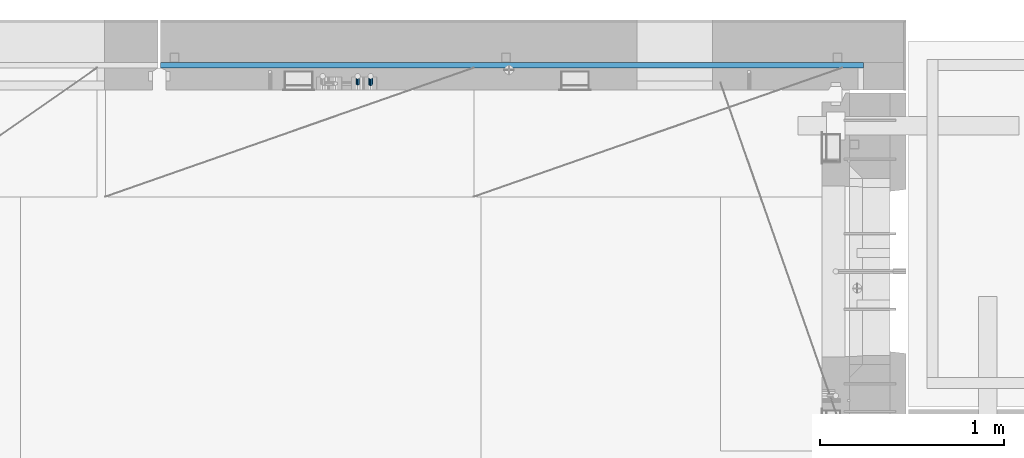
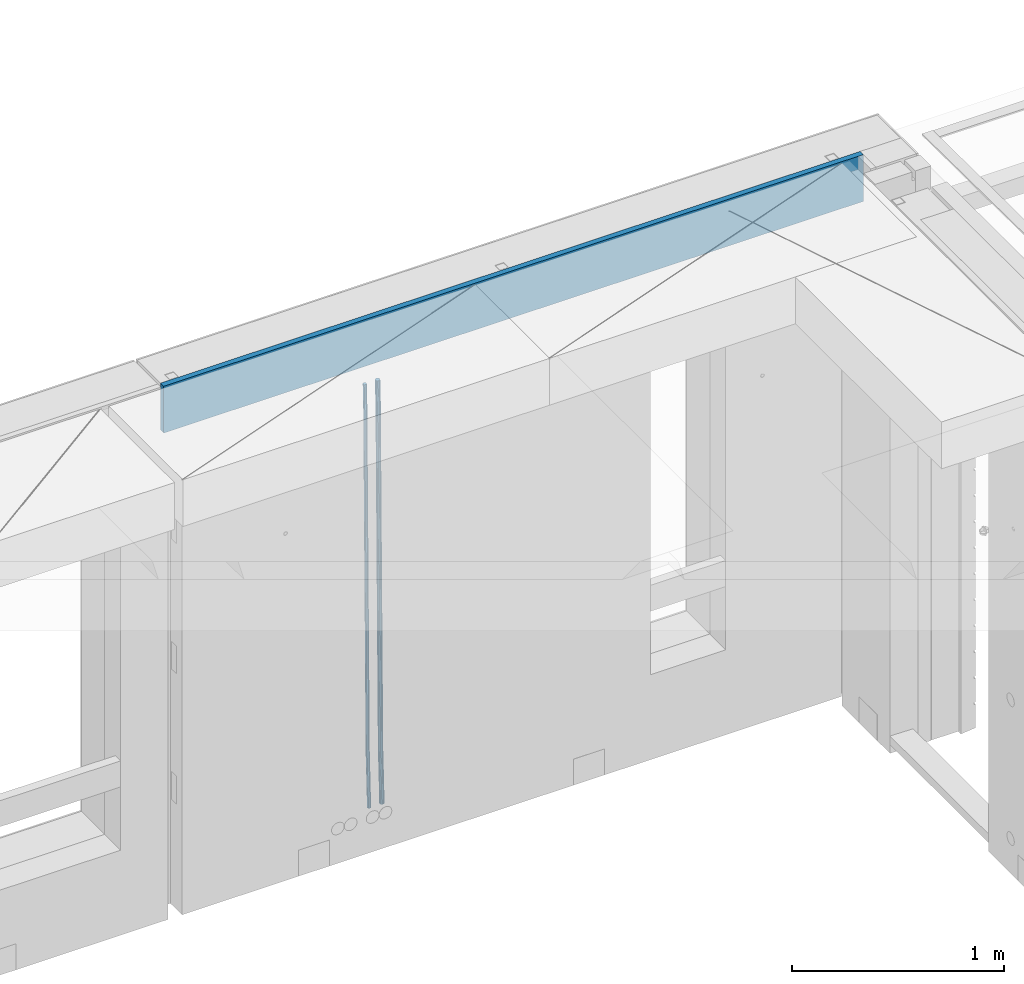
# One storey, part 128 of 349: 3 beams, 1 element without a shape of its own.
"""IFC2X3 building model written with IfcOpenShell, lengths in millimetres."""

from ifc_helpers import new_model, si_unit, frame, origin_with_axes, place, context, subcontext, project, spatial, faceted_brep, material, type_object, element, aggregate, save


model = new_model("IFC2X3")

# Units and contexts
model_context = context("Model", 3, precision=1e-05, world=origin_with_axes())
body_context = subcontext(model_context, "Body", "Model", "MODEL_VIEW")
ifc_project = project(units=[si_unit("LENGTHUNIT", "METRE", prefix="MILLI"), si_unit("AREAUNIT", "SQUARE_METRE"), si_unit("VOLUMEUNIT", "CUBIC_METRE"), si_unit("MASSUNIT", "GRAM", prefix="KILO"), si_unit("TIMEUNIT", "SECOND"), si_unit("PLANEANGLEUNIT", "RADIAN"), si_unit("SOLIDANGLEUNIT", "STERADIAN"), si_unit("THERMODYNAMICTEMPERATUREUNIT", "DEGREE_CELSIUS"), si_unit("LUMINOUSINTENSITYUNIT", "LUMEN")], contexts=[model_context])

# Site, building, storey
site_placement = place(None, origin_with_axes())
site = spatial("IfcSite", under=ifc_project, at=site_placement, CompositionType="ELEMENT")
building_placement = place(site_placement, origin_with_axes())
building = spatial("IfcBuilding", under=site, at=building_placement, CompositionType="ELEMENT")
storey_placement = place(building_placement, origin_with_axes())
storey = spatial("IfcBuildingStorey", under=building, at=storey_placement, Name="4", CompositionType="ELEMENT", Elevation=0.0)

# Assembly, beams
assembly_placement = place(storey_placement, origin_with_axes())
assembly = element("IfcElementAssembly", 1, at=assembly_placement, inside=storey, AssemblyPlace="NOTDEFINED", PredefinedType="REINFORCEMENT_UNIT")
ifc_material_1 = material()
beam_type_1 = type_object("IfcBeamType", Name="D20", PredefinedType="NOTDEFINED")
beam_1_placement = place(assembly_placement, frame((28790.0000000039, 22654.9999977209, 90990.0), z_axis=(-0.000205762999925498, 0.999642804629538, -0.0267249099901004), x_axis=(4.30000201928125e-08, 0.0267249099948059, 0.999642825806181)))
beam_1 = element("IfcBeam", 2, at=beam_1_placement, type_object=beam_type_1, material=ifc_material_1, Name="JM20", ObjectType="D20", context=body_context, shape_type="Brep", body=[
    faceted_brep([(0.0, -10.0, 0.0), (-4.19531716033816e-08, -7.07106781186667, -7.07106781187031), (60.4266690400545, -7.0710677960451, -7.07106780570757), (60.4266690441291, -9.99999998418934, 6.15546014159918e-09), (0.0, 0.0, -10.0), (60.426669036824, 1.58106558956206e-08, -9.99999999384454), (4.196772351861e-08, 7.07106781186303, -7.07106781186667), (60.4266690363438, 7.07106782768096, -7.07106780570757), (0.0, 10.0, 0.0), (60.4266690388904, 10.0000000158179, 6.15182216279209e-09), (4.196772351861e-08, 7.07106781185939, 7.07106781185939), (60.4266690429649, 7.07106782768096, 7.07106781802577), (0.0, 0.0, 10.0), (60.4266690461809, 1.58179318532348e-08, 10.0000000061555), (-4.19531716033816e-08, -7.07106781187031, 7.07106781185939), (60.4266690466611, -7.07106779605238, 7.07106781802213), (61.0378400410118, -7.07106779588503, -7.07106780564936), (60.991799419251, -9.99999998403655, 6.21366780251265e-09), (61.0569027789461, 1.5985278878361e-08, -9.99999999378269), (61.0378209396877, 7.07106782784831, -7.07106780564936), (60.9917724058905, 10.0000000159635, 6.21366780251265e-09), (60.9457317841297, 7.07106782781193, 7.0710678180767), (60.9266690461809, 1.59488990902901e-08, 10.0000000062028), (60.9457508854539, -7.07106779591413, 7.0710678180767), (61.6489592143771, -7.07106614513759, -7.06310863441468), (61.5568818710308, -9.9999984576425, 0.00735959856683621), (61.6870830769039, 1.71821739058942e-06, -9.99179257185824), (61.6489210170112, 7.07106947854481, -7.06310888312146), (61.556827851804, 10.0000015422847, 0.00735924683976918), (61.4647505084577, 7.07106922979438, 7.07782747982128), (61.4266266459163, 1.36643211590126e-06, 10.0065114172685), (61.464788705809, -7.07106639389531, 7.07782772852806), (176.543135720174, -7.07075579406956, -5.56673531796696), (176.451058376813, -9.99968810657447, 1.50373291501455), (176.581259582701, 0.000312069292704109, -8.49541925541052), (176.543097522794, 7.07137982961285, -5.56673556667374), (176.451004357587, 10.00031189336, 1.50373256329476), (176.35892701424, 7.07137958085514, 8.57420079627263), (176.320803151699, 0.000311717507429421, 11.5028847337162), (176.358965211621, -7.07075604281999, 8.57420104497578), (177.098753836006, -7.07075429323595, -5.55949898843028), (176.98362511232, -9.99968666800123, 1.510669025065), (177.146421932586, 0.000313595905026887, -8.48805862247536), (177.098706077581, 7.07138133041735, -5.55949936166144), (176.983557571715, 10.0003133318824, 1.51066849724157), (176.868428848029, 7.07138095712435, 8.58083651073321), (176.820760751449, 0.000313067976094317, 11.5093961447819), (176.868476606425, -7.07075466652896, 8.58083688396073), (177.654312950661, -7.07075204110879, -5.54863964998367), (177.516135294456, -9.99968450931192, 1.52107783331303), (177.711524267797, 0.000315886711177882, -8.47701274570863), (177.654255632195, 7.07138358250813, -5.54864021007961), (177.516054233929, 10.0003154905207, 1.5210770412159), (177.377876577739, 7.0713830223176, 8.59079452451624), (177.320665260588, 0.000315094497636892, 11.5191676202448), (177.377933896176, -7.07075260129932, 8.59079508461218), (299.436796249574, -7.07025836271714, -3.1681962331204), (299.298618593355, -9.99919083092027, 3.90152125031091), (299.494007566798, 0.000809565110102994, -6.09656932889993), (299.436738931283, 7.07187726089978, -3.16819679320906), (299.298537533061, 10.0008091689197, 3.90152045822106), (299.160359876842, 7.07187670072017, 10.9712379416487), (299.103148559603, 0.000808772889286047, 13.8996110374392), (299.160417195119, -7.07025892290039, 10.9712385017483), (299.98743051647, -7.07025613056248, -3.15743315966392), (299.971788958996, -9.99918809853989, 3.91467979818117), (299.993912075952, 0.000811591617093654, -6.08679785393178), (299.987423933868, 7.07187949325817, -3.1574327280432), (299.971753863239, 10.0008119014747, 3.91467990454839), (299.95611230444, 7.07187992653053, 10.9867922621015), (299.949630744944, 0.000812204350950196, 13.9161569563694), (299.956118887014, -7.07025569729012, 10.9867918304735), (300.538107039494, -7.07025785017686, -3.16575821840888), (300.644985195438, -9.99919020432935, 3.90450175465594), (300.493854948218, 0.000810030429420294, -6.09435592770024), (300.538151196495, 7.071877773491, -3.16575855385963), (300.645047642858, 10.0008097955724, 3.90450128024895), (300.751925798773, 7.07187744142357, 10.9747612533101), (300.796177890064, 0.000809560813650023, 13.9033589625978), (300.751881641787, -7.07025818224065, 10.9747615887682), (2293.36490490142, -7.07648090940347, -33.2930642912361), (2293.47178305736, -10.0054132635523, -26.2228043181785), (2293.32065281013, -0.00541302880083094, -36.2216620005347), (2293.36494905842, 7.06565471425711, -33.2930646266868), (2293.47184550477, 9.99458673634581, -26.2228047925819), (2293.57872366071, 7.06565438219332, -19.1525448195243), (2293.62297575199, -0.00541349841296324, -16.2239471102366), (2293.57867950371, -7.0764812414709, -19.1525444840736), (2294.0658245362, -7.07648309818615, -33.3036607065333), (2294.05312277409, -10.0054150789219, -26.2315929392535), (2294.10928714235, -0.00541549149056664, -36.2335844756526), (2294.15805078732, 7.06565223761572, -33.3050546393533), (2294.18355038921, 9.99458451388637, -26.2335642579346), (2294.17084862708, 7.06565253314329, -19.1614964906439), (2294.12738602093, -0.00541507354500936, -16.2315727215355), (2294.07862237596, -7.07648280265857, -19.1601025578348), (2294.76670261032, -7.08562269121467, -33.294332712383), (2294.63442802057, -10.0129954178956, -26.2238563411993), (2294.89787471293, -0.0156988342423574, -36.2230891548279), (2294.95110548967, 7.05531064255774, -33.2944998654275), (2294.89521307347, 9.98530428734011, -26.2240927312887), (2294.76293848372, 7.0579315606592, -19.1536163601049), (2294.63176638114, -0.0119922963167483, -16.2248599176673), (2294.57853560438, -7.08300177311321, -19.1534492070678), (2316.52657204497, -7.36937582653991, -33.0047303660212), (2316.39429745522, -10.2967485532172, -25.9342539948302), (2316.65774414754, -0.299451969567599, -35.9334868084661), (2316.7109749243, 6.7715575072325, -33.0048975190657), (2316.65508250811, 9.70155115201487, -25.9344903849269), (2316.52280791836, 6.7741784253376, -18.8640140137468), (2316.39163581574, -0.295745431634714, -15.9352575713092), (2316.33840503903, -7.36675490843481, -18.863846860706), (2317.16202064224, -7.37766220584308, -32.9962731735213), (2317.05438744847, -10.3053562613532, -25.9254688497131), (2317.23607125619, -0.306993473008333, -35.925789846493), (2317.23316144495, 6.76474808850253, -32.9979477328052), (2317.15499573652, 9.6950321815566, -25.9278370341635), (2317.04736254275, 6.7673381260538, -18.8570327103698), (2316.97331192881, -0.303330606784584, -15.9275160373909), (2316.97622174003, -7.37507216829545, -18.8553581510787), (2317.79752306276, -7.37578610372293, -32.9880110666527), (2317.71453320107, -10.3033876998124, -25.9168792378296), (2317.81444760226, -0.305295583297266, -35.918287695793), (2317.75539265381, 6.76628640723357, -32.9911928173897), (2317.65495180529, 9.69652304524061, -25.9213789128698), (2317.5719619436, 6.76892144914746, -18.8502470840467), (2317.55503740412, -0.301569071270933, -15.9199704549137), (2317.61409235255, -7.3731510618054, -18.847065333317), (2417.8183084176, -7.07752398473531, -31.6906369377139), (2417.73531855589, -10.0051255808248, -24.6195051088798), (2417.83523295709, -0.007033464313281, -34.6209135668432), (2417.77617800863, 7.06454852621755, -31.6938186884508), (2417.67573716014, 9.99478516423187, -24.6240047839383), (2417.59274729842, 7.06718356813872, -17.5528729551006), (2417.57582275895, -0.00330695228694822, -14.6225963259749), (2417.6348777074, -7.07488894281778, -17.5496912043673)], [[[0, 1, 2, 3]], [[1, 4, 5, 2]], [[4, 6, 7, 5]], [[6, 8, 9, 7]], [[8, 10, 11, 9]], [[10, 12, 13, 11]], [[12, 14, 15, 13]], [[14, 0, 3, 15]], [[14, 12, 10, 8, 6, 4, 1, 0]], [[3, 2, 16, 17]], [[2, 5, 18, 16]], [[5, 7, 19, 18]], [[7, 9, 20, 19]], [[9, 11, 21, 20]], [[11, 13, 22, 21]], [[13, 15, 23, 22]], [[15, 3, 17, 23]], [[17, 16, 24, 25]], [[16, 18, 26, 24]], [[18, 19, 27, 26]], [[19, 20, 28, 27]], [[20, 21, 29, 28]], [[21, 22, 30, 29]], [[22, 23, 31, 30]], [[23, 17, 25, 31]], [[25, 24, 32, 33]], [[24, 26, 34, 32]], [[26, 27, 35, 34]], [[27, 28, 36, 35]], [[28, 29, 37, 36]], [[29, 30, 38, 37]], [[30, 31, 39, 38]], [[31, 25, 33, 39]], [[33, 32, 40, 41]], [[32, 34, 42, 40]], [[34, 35, 43, 42]], [[35, 36, 44, 43]], [[36, 37, 45, 44]], [[37, 38, 46, 45]], [[38, 39, 47, 46]], [[39, 33, 41, 47]], [[41, 40, 48, 49]], [[40, 42, 50, 48]], [[42, 43, 51, 50]], [[43, 44, 52, 51]], [[44, 45, 53, 52]], [[45, 46, 54, 53]], [[46, 47, 55, 54]], [[47, 41, 49, 55]], [[49, 48, 56, 57]], [[48, 50, 58, 56]], [[50, 51, 59, 58]], [[51, 52, 60, 59]], [[52, 53, 61, 60]], [[53, 54, 62, 61]], [[54, 55, 63, 62]], [[55, 49, 57, 63]], [[57, 56, 64, 65]], [[56, 58, 66, 64]], [[58, 59, 67, 66]], [[59, 60, 68, 67]], [[60, 61, 69, 68]], [[61, 62, 70, 69]], [[62, 63, 71, 70]], [[63, 57, 65, 71]], [[65, 64, 72, 73]], [[64, 66, 74, 72]], [[66, 67, 75, 74]], [[67, 68, 76, 75]], [[68, 69, 77, 76]], [[69, 70, 78, 77]], [[70, 71, 79, 78]], [[71, 65, 73, 79]], [[73, 72, 80, 81]], [[72, 74, 82, 80]], [[74, 75, 83, 82]], [[75, 76, 84, 83]], [[76, 77, 85, 84]], [[77, 78, 86, 85]], [[78, 79, 87, 86]], [[79, 73, 81, 87]], [[81, 80, 88, 89]], [[80, 82, 90, 88]], [[82, 83, 91, 90]], [[83, 84, 92, 91]], [[84, 85, 93, 92]], [[85, 86, 94, 93]], [[86, 87, 95, 94]], [[87, 81, 89, 95]], [[89, 88, 96, 97]], [[88, 90, 98, 96]], [[90, 91, 99, 98]], [[91, 92, 100, 99]], [[92, 93, 101, 100]], [[93, 94, 102, 101]], [[94, 95, 103, 102]], [[95, 89, 97, 103]], [[97, 96, 104, 105]], [[96, 98, 106, 104]], [[98, 99, 107, 106]], [[99, 100, 108, 107]], [[100, 101, 109, 108]], [[101, 102, 110, 109]], [[102, 103, 111, 110]], [[103, 97, 105, 111]], [[105, 104, 112, 113]], [[104, 106, 114, 112]], [[106, 107, 115, 114]], [[107, 108, 116, 115]], [[108, 109, 117, 116]], [[109, 110, 118, 117]], [[110, 111, 119, 118]], [[111, 105, 113, 119]], [[113, 112, 120, 121]], [[112, 114, 122, 120]], [[114, 115, 123, 122]], [[115, 116, 124, 123]], [[116, 117, 125, 124]], [[117, 118, 126, 125]], [[118, 119, 127, 126]], [[119, 113, 121, 127]], [[121, 120, 128, 129]], [[120, 122, 130, 128]], [[122, 123, 131, 130]], [[123, 124, 132, 131]], [[124, 125, 133, 132]], [[125, 126, 134, 133]], [[126, 127, 135, 134]], [[127, 121, 129, 135]], [[130, 131, 132, 133, 134, 135, 129, 128]]]),
])
beam_type_2 = type_object("IfcBeamType", Name="D25", PredefinedType="NOTDEFINED")
beam_2_placement = place(assembly_placement, frame((28860.0000000039, 22654.9999977209, 90990.0), z_axis=(-0.000205762999925498, 0.999642804629538, -0.0267249099901004), x_axis=(4.30000201928125e-08, 0.0267249099948059, 0.999642825806181)))
beam_2 = element("IfcBeam", 3, at=beam_2_placement, type_object=beam_type_2, material=ifc_material_1, Name="JM25", ObjectType="D25", context=body_context, shape_type="Brep", body=[
    faceted_brep([(-7.41420080885291e-08, -12.5, -3.63797880709171e-12), (-6.42030499875546e-08, -10.8253175473074, -6.25000000000364), (60.4103898235917, -10.8253175318459, -6.2499999938409), (60.4103898269532, -12.4999999845422, 6.16273609921336e-09), (-3.70782800018787e-08, -6.25000000000364, -10.8253175473074), (60.4103898202884, -6.24999998454587, -10.8253175411446), (-1.45519152283669e-11, -3.63797880709171e-12, -12.5), (60.4103898179019, 1.54577719513327e-08, -12.4999999938373), (3.70637280866504e-08, 6.25, -10.8253175473074), (60.410389817087, 6.25000001545777, -10.825317541141), (6.42030499875546e-08, 10.8253175473001, -6.25000000000364), (60.410389818062, 10.8253175627578, -6.24999999383726), (7.41420080885291e-08, 12.4999999999927, 0.0), (60.4103898205503, 12.5000000154541, 6.16273609921336e-09), (6.42176019027829e-08, 10.8253175473001, 6.24999999999636), (60.4103898238973, 10.8253175627651, 6.2500000061591), (3.70928319171071e-08, 6.24999999999636, 10.8253175473037), (60.4103898272151, 6.25000001546141, 10.8253175534664), (1.45519152283669e-11, -3.63797880709171e-12, 12.4999999999964), (60.4103898296162, 1.54541339725256e-08, 12.5000000061591), (-3.7049176171422e-08, -6.25000000000364, 10.8253175473001), (60.4103898304165, -6.24999998454587, 10.8253175534701), (-6.41884980723262e-08, -10.8253175473074, 6.25), (60.4103898294561, -10.8253175318459, 6.25000000616637), (61.0324985728803, -10.8253175316895, -6.24999999377542), (60.991802792938, -12.4999999843931, 6.22458173893392e-09), (61.0622854283865, -6.24999998437852, -10.8253175410755), (61.0731819955545, 1.5628756955266e-08, -12.4999999937718), (61.0622685480339, 6.25000001562512, -10.8253175410791), (61.032469335245, 10.8253175629216, -6.24999999377178), (60.9917690322181, 12.5000000156033, 6.22458173893392e-09), (60.9510732522613, 10.8253175629034, 6.25000000621731), (60.9212863967696, 6.25000001558874, 10.8253175535247), (60.9103898296162, 1.55814632307738e-08, 12.5000000062137), (60.9213032771368, -6.24999998441126, 10.8253175535174), (60.9511024898966, -10.8253175317113, 6.25000000621731), (61.6545545670233, -10.8253158516927, -6.24189838219536), (61.573166454793, -12.499998414296, 0.00757164385504439), (61.7141257553885, -6.24999822394238, -10.8168280205282), (61.7359179680789, 1.80548886419274e-06, -12.491368569139), (61.7140919992817, 6.25000177601396, -10.8168282403167), (61.6544960997562, 10.8253192428383, -6.2418987628771), (61.5730989426083, 12.5000015856094, 0.0075712042817031), (61.4917108303925, 10.8253190230062, 6.25704123032847), (61.4321396420273, 6.25000139525582, 10.8319708686649), (61.4103474293224, 1.36582457344048e-06, 12.5065114172721), (61.4321733981196, -6.24999860470052, 10.8319710884571), (61.4917692976451, -10.8253160715249, 6.25704161101385), (176.524302641745, -10.8250056210964, -4.74584321979273), (176.442914529529, -12.4996881836996, 1.50362680625403), (176.583873830095, -6.24968799334965, -9.3207728581292), (176.605666042786, 0.000312036081595579, -10.9953134067364), (176.583840074018, 6.25031200660669, -9.32077307791769), (176.524244174492, 10.8256294734347, -4.74584360047811), (176.44284701733, 12.5003118162058, 1.50362636668069), (176.361458905099, 10.8256292535989, 7.75309639272746), (176.301887716749, 6.25031162585219, 12.3280260310676), (176.280095504058, 0.000311596420942806, 14.0025665796711), (176.301921472827, -6.24968837410415, 12.3280262508561), (176.361517372367, -10.8250058409321, 7.75309677341284), (177.085397012124, -10.8250041057399, -4.73853556792164), (176.983633547483, -12.4996867233749, 1.51066909103247), (177.159881729676, -6.24968643771717, -9.31327097355097), (177.187129580227, 0.000313606451527448, -10.987740468332), (177.159839524218, 6.25031356221734, -9.31327130338468), (177.085323910098, 10.8256309887511, -4.73853613920801), (176.983549136537, 12.5003132764905, 1.51066843136869), (176.881785671867, 10.8256306588555, 7.7598730903228), (176.80730095433, 6.25031299082912, 12.3346084959521), (176.780053103794, 0.000312946667690994, 14.0090779907332), (176.807343159802, -6.2496870091054, 12.3346088257895), (176.881858773908, -10.8250044356355, 7.7598736616128), (177.646431799818, -10.8250018318176, -4.72756919822132), (177.524295146417, -12.4996845320202, 1.52123723245313), (177.735828462886, -6.24968410334986, -9.30201312475765), (177.768531371941, 0.00031596292683389, -10.9763759912421), (177.735777808921, 6.25031589654827, -9.30201361973741), (177.646344064575, 10.8256332626152, -4.72757005553649), (177.524193838486, 12.5003154677688, 1.52123624250817), (177.402057185071, 10.8256327675663, 7.77004267317898), (177.312660521988, 6.2503150390985, 12.3444865997226), (177.279957612933, 0.00031497282179771, 14.0188494661961), (177.312711175953, -6.24968496079964, 12.3444870946951), (177.402144920314, -10.8250023268702, 7.77004353049415), (299.377443161706, -10.8245084454466, -2.34813158632096), (299.255306508276, -12.4991911456491, 3.90067484435349), (299.466839824803, -6.24919071697514, -6.92257551286093), (299.499542733873, 0.0008093492979242, -8.59693837933446), (299.466789170867, 6.250809282923, -6.92257600783341), (299.377355426492, 10.8261266489935, -2.34813244364341), (299.255205200388, 12.5008088541435, 3.90067385440125), (299.133068546944, 10.826126153941, 10.1494802850757), (299.043671883861, 6.25080842546959, 14.7239242116229), (299.010968974762, 0.000808359200163977, 16.3982870780892), (299.043722537797, -6.24919157442127, 14.7239247065918), (299.133156282158, -10.8245089404954, 10.1494811423981), (299.98561436501, -10.8245059804758, -2.33624385599614), (299.97179243555, -12.4991882411778, 3.91467976726199), (299.995742293278, -6.24918857328521, -6.91223722345239), (299.999447243041, 0.000811375455668895, -8.58716690387519), (299.995736475976, 6.25081142679483, -6.91223684201032), (299.985604289133, 10.8261291142808, -2.33624319533556), (299.971750386685, 12.5008117588586, 3.91467993563856), (299.957928457196, 10.8261294971744, 10.1656035610831), (299.947800528913, 6.25081208998381, 14.7415969285394), (299.944095579151, 0.00081214124293183, 16.4165266089549), (299.947806346216, -6.24918791008895, 14.7415965471009), (299.957938533058, -10.8245055975785, 10.1656029004225), (300.593832239858, -10.8245078794353, -2.34543881707941), (300.688302931099, -12.4991904788549, 3.90384712594823), (300.524685350189, -6.24919022474205, -6.92023371784308), (300.499390115292, 0.000809814544481924, -8.59472497713432), (300.524724372954, 6.25080977519247, -6.92023401429469), (300.593899829313, 10.8261272150703, -2.34543933054374), (300.688380976673, 12.5008095210287, 3.90384653304136), (300.782851667915, 10.8261269216127, 10.1531324760799), (300.851998557599, 6.25080926691589, 14.7279273768363), (300.877293792495, 0.000809227632998955, 16.4024186361276), (300.851959534804, -6.24919073302226, 14.7279276732806), (300.782784078474, -10.8245081728965, 10.153132989537), (2293.32930409742, -10.8307295605009, -32.4713622331001), (2293.42377478865, -12.5054121599169, -26.2220762900724), (2293.26015720774, -6.2554119058077, -37.0461571338565), (2293.23486197284, -0.00541186651753378, -38.7206483931477), (2293.26019623051, 6.24458809413409, -37.0461574303008), (2293.32937168686, 10.8199055340046, -32.4713627465644), (2293.42385283421, 12.4945878399631, -26.2220768829684), (2293.51832352545, 10.8199052405434, -19.972790939948), (2293.58747041514, 6.24458758585388, -15.3979960391844), (2293.61276565003, -0.00541245343265473, -13.7235047798931), (2293.58743139236, -6.25541241408428, -15.3979957427327), (2293.51825593603, -10.8307298539585, -19.9727904264691), (2294.0420846676, -10.8307317859326, -32.4821379598216), (2294.03681932652, -12.5054140739521, -26.2313442200393), (2294.06778164886, -6.2554144273563, -37.0583666982457), (2294.10702478497, -0.00541458957013674, -38.7338336404937), (2294.14929890928, 6.24458531819619, -37.0595987724118), (2294.18327670435, 10.8199028679592, -32.4842719748667), (2294.1998538474, 12.4945854171456, -26.2338083683717), (2294.19458850632, 10.819903129126, -19.9830146285858), (2294.16889152506, 6.24458577054975, -15.4067858901581), (2294.12964838895, -0.0054140672327776, -13.7313189479173), (2294.08737426462, -6.2554139749991, -15.4055538159919), (2294.05339646956, -10.8307315247621, -19.9808806135297), (2294.75482297382, -10.84002603931, -32.4726521173216), (2294.64982751427, -12.513407826169, -26.2231856868602), (2294.87535820232, -6.26594539088183, -37.0476186524102), (2294.97913588268, -0.0167870967634371, -38.7222267036377), (2295.0383488692, 6.23299192477134, -37.0477663960555), (2295.03713108998, 10.8087684320271, -32.4729080168181), (2294.97580884799, 12.4844668051373, -26.2234811741473), (2294.87081338844, 10.8110850182784, -19.9740147436787), (2294.7502781599, 6.23700436985018, -15.3990482086047), (2294.64650047956, -0.0121539242718427, -13.7244401573698), (2294.58728749304, -6.26193294580662, -15.3989004649666), (2294.58850527227, -10.8377094530588, -19.9737588441894), (2316.44667268227, -11.1228921988077, -32.1839550346631), (2316.34167722271, -12.7962739856739, -25.9344886042054), (2316.56720791078, -6.54881155039038, -36.7589215697517), (2316.67098559113, -0.299653256264719, -38.4335296209792), (2316.73019857766, 5.95012576527006, -36.759069313397), (2316.72898079845, 10.5259022725259, -32.1842109341669), (2316.66765855643, 12.2016006456361, -25.9347840914961), (2316.56266309689, 10.5282188587698, -19.6853176610275), (2316.44212786836, 5.95413821035254, -15.1103511259389), (2316.33835018802, -0.295020083769487, -13.4357430747186), (2316.27913720149, -6.54479910530426, -15.1102033823008), (2316.28035498071, -11.1205756125637, -19.685061761531), (2317.13234804722, -11.1318335458927, -32.1748293731798), (2317.04181141085, -12.8054038787741, -25.9251705100723), (2317.2154741603, -6.5572650749491, -36.7502937866229), (2317.26891617525, -0.307450393454928, -38.4255717558117), (2317.27835434731, 5.94297770185585, -36.7517739018112), (2317.24125972588, 10.5192220504723, -32.1773930078925), (2317.16757178486, 12.1950816748285, -25.9281307404563), (2317.0770351485, 10.5215113419545, -19.6784718773561), (2316.99390903539, 5.94694287101083, -15.1030074639057), (2316.94046702047, -0.302871810494253, -13.4277294947169), (2316.9310288484, -6.55329990579412, -15.1015273487101), (2316.96812346982, -11.1295442544142, -19.6759082426288), (2317.81808136747, -11.1298054502913, -32.1659056455355), (2317.74200467508, -12.803315894289, -25.9160547315114), (2317.86379538118, -6.55536082026447, -36.7418676070083), (2317.8668976831, -0.305700748642266, -38.417815303761), (2317.82655701396, 5.94458339541234, -36.7446799039099), (2317.75358262347, 10.5207330230332, -32.1707766866384), (2317.66752794063, 12.1965725370646, -25.9216793252963), (2317.59145124823, 10.5230620930706, -19.6718284112721), (2317.54573723453, 5.94861746304377, -15.0958664497994), (2317.54263493262, -0.301042608574789, -13.4199187530394), (2317.58297560175, -6.55132675263303, -15.0930541529051), (2317.65594999224, -11.1274763802539, -19.6669573701693), (2417.81884292323, -10.831603083323, -30.8687911350135), (2417.74276623082, -12.505113527317, -24.618940220982), (2417.86455693691, -6.25715845329614, -35.4447530964935), (2417.86765923884, -0.00749838167394046, -37.1207007932499), (2417.82731856969, 6.24278576237703, -35.4475653933878), (2417.75434417921, 10.8189353900088, -30.8736621761236), (2417.66828949639, 12.494774904033, -24.6245648147851), (2417.59221280397, 10.8212644600353, -18.3747139007501), (2417.54649879028, 6.2468198300121, -13.79875193927), (2417.54339648837, -0.00284024161010166, -12.1228042425173), (2417.5837371575, -6.25312438566107, -13.795939642383), (2417.65671154798, -10.8292740132893, -18.3698428596399)], [[[0, 1, 2, 3]], [[1, 4, 5, 2]], [[4, 6, 7, 5]], [[6, 8, 9, 7]], [[8, 10, 11, 9]], [[10, 12, 13, 11]], [[12, 14, 15, 13]], [[14, 16, 17, 15]], [[16, 18, 19, 17]], [[18, 20, 21, 19]], [[20, 22, 23, 21]], [[22, 0, 3, 23]], [[22, 20, 18, 16, 14, 12, 10, 8, 6, 4, 1, 0]], [[3, 2, 24, 25]], [[2, 5, 26, 24]], [[5, 7, 27, 26]], [[7, 9, 28, 27]], [[9, 11, 29, 28]], [[11, 13, 30, 29]], [[13, 15, 31, 30]], [[15, 17, 32, 31]], [[17, 19, 33, 32]], [[19, 21, 34, 33]], [[21, 23, 35, 34]], [[23, 3, 25, 35]], [[25, 24, 36, 37]], [[24, 26, 38, 36]], [[26, 27, 39, 38]], [[27, 28, 40, 39]], [[28, 29, 41, 40]], [[29, 30, 42, 41]], [[30, 31, 43, 42]], [[31, 32, 44, 43]], [[32, 33, 45, 44]], [[33, 34, 46, 45]], [[34, 35, 47, 46]], [[35, 25, 37, 47]], [[37, 36, 48, 49]], [[36, 38, 50, 48]], [[38, 39, 51, 50]], [[39, 40, 52, 51]], [[40, 41, 53, 52]], [[41, 42, 54, 53]], [[42, 43, 55, 54]], [[43, 44, 56, 55]], [[44, 45, 57, 56]], [[45, 46, 58, 57]], [[46, 47, 59, 58]], [[47, 37, 49, 59]], [[49, 48, 60, 61]], [[48, 50, 62, 60]], [[50, 51, 63, 62]], [[51, 52, 64, 63]], [[52, 53, 65, 64]], [[53, 54, 66, 65]], [[54, 55, 67, 66]], [[55, 56, 68, 67]], [[56, 57, 69, 68]], [[57, 58, 70, 69]], [[58, 59, 71, 70]], [[59, 49, 61, 71]], [[61, 60, 72, 73]], [[60, 62, 74, 72]], [[62, 63, 75, 74]], [[63, 64, 76, 75]], [[64, 65, 77, 76]], [[65, 66, 78, 77]], [[66, 67, 79, 78]], [[67, 68, 80, 79]], [[68, 69, 81, 80]], [[69, 70, 82, 81]], [[70, 71, 83, 82]], [[71, 61, 73, 83]], [[73, 72, 84, 85]], [[72, 74, 86, 84]], [[74, 75, 87, 86]], [[75, 76, 88, 87]], [[76, 77, 89, 88]], [[77, 78, 90, 89]], [[78, 79, 91, 90]], [[79, 80, 92, 91]], [[80, 81, 93, 92]], [[81, 82, 94, 93]], [[82, 83, 95, 94]], [[83, 73, 85, 95]], [[85, 84, 96, 97]], [[84, 86, 98, 96]], [[86, 87, 99, 98]], [[87, 88, 100, 99]], [[88, 89, 101, 100]], [[89, 90, 102, 101]], [[90, 91, 103, 102]], [[91, 92, 104, 103]], [[92, 93, 105, 104]], [[93, 94, 106, 105]], [[94, 95, 107, 106]], [[95, 85, 97, 107]], [[97, 96, 108, 109]], [[96, 98, 110, 108]], [[98, 99, 111, 110]], [[99, 100, 112, 111]], [[100, 101, 113, 112]], [[101, 102, 114, 113]], [[102, 103, 115, 114]], [[103, 104, 116, 115]], [[104, 105, 117, 116]], [[105, 106, 118, 117]], [[106, 107, 119, 118]], [[107, 97, 109, 119]], [[109, 108, 120, 121]], [[108, 110, 122, 120]], [[110, 111, 123, 122]], [[111, 112, 124, 123]], [[112, 113, 125, 124]], [[113, 114, 126, 125]], [[114, 115, 127, 126]], [[115, 116, 128, 127]], [[116, 117, 129, 128]], [[117, 118, 130, 129]], [[118, 119, 131, 130]], [[119, 109, 121, 131]], [[121, 120, 132, 133]], [[120, 122, 134, 132]], [[122, 123, 135, 134]], [[123, 124, 136, 135]], [[124, 125, 137, 136]], [[125, 126, 138, 137]], [[126, 127, 139, 138]], [[127, 128, 140, 139]], [[128, 129, 141, 140]], [[129, 130, 142, 141]], [[130, 131, 143, 142]], [[131, 121, 133, 143]], [[133, 132, 144, 145]], [[132, 134, 146, 144]], [[134, 135, 147, 146]], [[135, 136, 148, 147]], [[136, 137, 149, 148]], [[137, 138, 150, 149]], [[138, 139, 151, 150]], [[139, 140, 152, 151]], [[140, 141, 153, 152]], [[141, 142, 154, 153]], [[142, 143, 155, 154]], [[143, 133, 145, 155]], [[145, 144, 156, 157]], [[144, 146, 158, 156]], [[146, 147, 159, 158]], [[147, 148, 160, 159]], [[148, 149, 161, 160]], [[149, 150, 162, 161]], [[150, 151, 163, 162]], [[151, 152, 164, 163]], [[152, 153, 165, 164]], [[153, 154, 166, 165]], [[154, 155, 167, 166]], [[155, 145, 157, 167]], [[157, 156, 168, 169]], [[156, 158, 170, 168]], [[158, 159, 171, 170]], [[159, 160, 172, 171]], [[160, 161, 173, 172]], [[161, 162, 174, 173]], [[162, 163, 175, 174]], [[163, 164, 176, 175]], [[164, 165, 177, 176]], [[165, 166, 178, 177]], [[166, 167, 179, 178]], [[167, 157, 169, 179]], [[169, 168, 180, 181]], [[168, 170, 182, 180]], [[170, 171, 183, 182]], [[171, 172, 184, 183]], [[172, 173, 185, 184]], [[173, 174, 186, 185]], [[174, 175, 187, 186]], [[175, 176, 188, 187]], [[176, 177, 189, 188]], [[177, 178, 190, 189]], [[178, 179, 191, 190]], [[179, 169, 181, 191]], [[181, 180, 192, 193]], [[180, 182, 194, 192]], [[182, 183, 195, 194]], [[183, 184, 196, 195]], [[184, 185, 197, 196]], [[185, 186, 198, 197]], [[186, 187, 199, 198]], [[187, 188, 200, 199]], [[188, 189, 201, 200]], [[189, 190, 202, 201]], [[190, 191, 203, 202]], [[191, 181, 193, 203]], [[194, 195, 196, 197, 198, 199, 200, 201, 202, 203, 193, 192]]]),
])
ifc_material_2 = material(Name="CONCRETE/C25/30")
beam_type_3 = type_object("IfcBeamType", Name="270X30", PredefinedType="NOTDEFINED")
beam_3_placement = place(assembly_placement, frame((31535.0, 22755.0, 93605.0), z_axis=(0.0, 0.0, 1.0), x_axis=(-1.0, 3.00000001838171e-08, 0.0)))
beam_3 = element("IfcBeam", 4, at=beam_3_placement, type_object=beam_type_3, material=ifc_material_2, ObjectType="270X30", context=body_context, shape_type="Brep", body=[
    faceted_brep([(0.0, 15.0, -135.0), (0.0, 15.0, 135.0), (3815.00000000003, 15.0, 135.0), (3815.00000000003, 15.0, -135.0), (0.0, -15.0, 135.0), (3815.00000000003, -15.0, 135.0), (0.0, -15.0, -135.0), (3815.00000000003, -15.0, -135.0)], [[[0, 1, 2, 3]], [[1, 4, 5, 2]], [[4, 6, 7, 5]], [[6, 0, 3, 7]], [[5, 7, 3, 2]], [[6, 4, 1, 0]]]),
])
aggregate(assembly, [beam_1, beam_2, beam_3])

save(model, "model.ifc")
